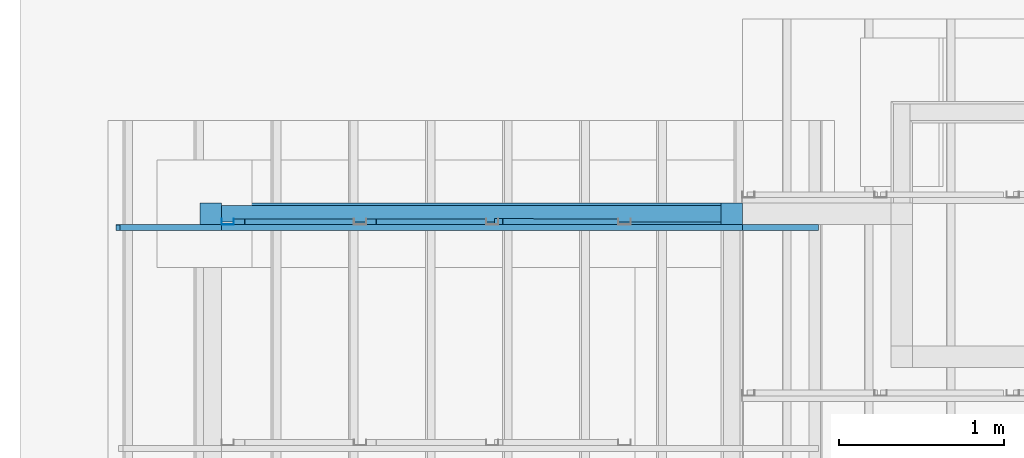
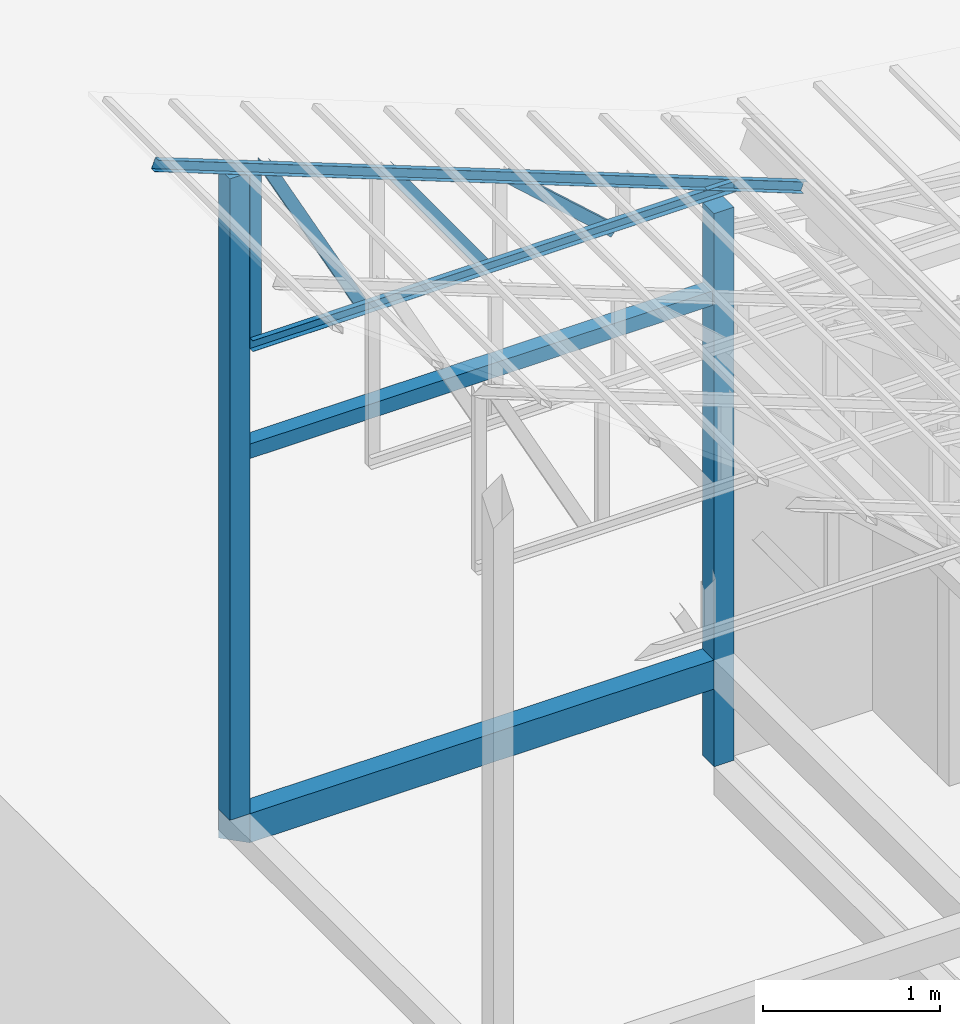
# One storey, part 14 of 22: 6 members, 4 beams, 1 element without a shape of its own.
"""IFC4 building model written with IfcOpenShell, lengths in millimetres."""

import ifcopenshell
import ifcopenshell.guid

model = None  # the IFC model being written
_history = None  # IfcOwnerHistory: only IFC2X3 demands one
_inside = {}  # id of a spatial element -> (the spatial element, [elements in it])
_under = {}  # id of a project, library or spatial element -> (it, [spatial elements below it])
_declared = {}  # id of a project -> (the project, [libraries it declares])
_typed = {}  # id of a type object -> (the type object, [elements of that type])
_made_of = {}  # id of a material, layer set ... -> (it, [elements and type objects made of it])


def new_model(schema):
    """Start an empty IFC model of exactly this schema.

    Asked for "IFC4X3", IfcOpenShell would pick the latest addendum, in which some entities
    have other attributes; the version numbers below select the first issue.
    IFC2X3 requires an IfcOwnerHistory on every rooted entity: one is made here for all.
    """
    global model, _history
    if schema == "IFC4X3":
        model = ifcopenshell.file(schema_version=(4, 3, 0, 0))
    else:
        model = ifcopenshell.file(schema=schema)
    _inside.clear()
    _under.clear()
    _declared.clear()
    _typed.clear()
    _made_of.clear()
    _history = None
    if model.schema == "IFC2X3":
        org = make("IfcOrganization", Name="unknown")
        user = make(
            "IfcPersonAndOrganization",
            ThePerson=make("IfcPerson", FamilyName="unknown"),
            TheOrganization=org,
        )
        app = make(
            "IfcApplication",
            ApplicationDeveloper=org,
            Version="unknown",
            ApplicationFullName="unknown",
            ApplicationIdentifier="unknown",
        )
        _history = make(
            "IfcOwnerHistory",
            OwningUser=user,
            OwningApplication=app,
            ChangeAction="ADDED",
            CreationDate=0,
        )
    return model


def make(cls, **values):
    """One entity of the class cls with the attributes given. An attribute that is None is left unset."""
    return model.create_entity(
        cls, **{name: value for name, value in values.items() if value is not None}
    )


def entity(cls, *values):
    """Any entity or typed value of the class cls, its attributes in the order of the schema. None: left unset."""
    e = model.create_entity(cls)
    for i, value in enumerate(values):
        if value is not None:
            e[i] = value
    return e


def rooted(cls, **values):
    """An entity with a GlobalId (a new one), such as an element, a storey or a relation."""
    return make(cls, GlobalId=ifcopenshell.guid.new(), OwnerHistory=_history, **values)


def si_unit(unit_type, name, prefix=None):
    """IfcSIUnit, for example si_unit("LENGTHUNIT", "METRE", prefix="MILLI")."""
    return make("IfcSIUnit", UnitType=unit_type, Prefix=prefix, Name=name)


def converted_unit(unit_type, name, factor, base, dimensions=None, offset=None):
    """IfcConversionBasedUnit, such as the inch: factor (a typed value) times the base unit."""
    return make(
        "IfcConversionBasedUnit"
        if offset is None
        else "IfcConversionBasedUnitWithOffset",
        ConversionOffset=offset,
        Dimensions=None
        if dimensions is None
        else entity("IfcDimensionalExponents", *dimensions),
        UnitType=unit_type,
        Name=name,
        ConversionFactor=make(
            "IfcMeasureWithUnit", ValueComponent=factor, UnitComponent=base
        ),
    )


def assignment(units):
    """IfcUnitAssignment: the units of a project."""
    return None if units is None else make("IfcUnitAssignment", Units=units)


def point(xyz):
    """IfcCartesianPoint."""
    return None if xyz is None else make("IfcCartesianPoint", Coordinates=xyz)


def direction(xyz):
    """IfcDirection."""
    return None if xyz is None else make("IfcDirection", DirectionRatios=xyz)


def frame(location, z_axis=None, x_axis=None):
    """IfcAxis2Placement3D, a coordinate frame: its origin and axes. An axis left out is left unset."""
    return make(
        "IfcAxis2Placement3D",
        Location=point(location),
        Axis=direction(z_axis),
        RefDirection=direction(x_axis),
    )


def frame_2d(location, x_axis=None):
    """IfcAxis2Placement2D, a coordinate frame in the plane: its origin and x axis."""
    return make(
        "IfcAxis2Placement2D", Location=point(location), RefDirection=direction(x_axis)
    )


def origin_with_axes():
    """The frame at (0, 0, 0) with the z axis (0, 0, 1) and the x axis (1, 0, 0) written out."""
    return frame((0.0, 0.0, 0.0), z_axis=(0.0, 0.0, 1.0), x_axis=(1.0, 0.0, 0.0))


def origin_2d_with_axis():
    """The frame at (0, 0) in the plane with the x axis (1, 0) written out."""
    return frame_2d((0.0, 0.0), x_axis=(1.0, 0.0))


def place(relative_to, where):
    """IfcLocalPlacement: puts the frame where relative to a parent placement (None: the world)."""
    return make(
        "IfcLocalPlacement", PlacementRelTo=relative_to, RelativePlacement=where
    )


def context(
    kind, dimensions, precision=None, world=None, true_north=None, identifier=None
):
    """IfcGeometricRepresentationContext, for example the 3D "Model" context."""
    return make(
        "IfcGeometricRepresentationContext",
        ContextIdentifier=identifier,
        ContextType=kind,
        CoordinateSpaceDimension=dimensions,
        Precision=precision,
        WorldCoordinateSystem=world,
        TrueNorth=true_north,
    )


def subcontext(parent, identifier, kind, view, scale=None):
    """IfcGeometricRepresentationSubContext, for example "Body" below "Model"."""
    return make(
        "IfcGeometricRepresentationSubContext",
        ContextIdentifier=identifier,
        ContextType=kind,
        ParentContext=parent,
        TargetScale=scale,
        TargetView=view,
    )


def project(units=None, contexts=None):
    """IfcProject with its units and contexts."""
    return rooted(
        "IfcProject",
        Name="project",
        RepresentationContexts=contexts,
        UnitsInContext=assignment(units),
    )


def spatial(cls, under=None, at=None, **own):
    """A site, building, storey or space (cls), placed at a placement, below another one or the project."""
    s = rooted(cls, ObjectPlacement=at, **own)
    if under is not None:
        _under.setdefault(under.id(), (under, []))[1].append(s)
    return s


def point_list(points):
    """IfcCartesianPointList2D or 3D."""
    cls = (
        "IfcCartesianPointList2D" if len(points[0]) == 2 else "IfcCartesianPointList3D"
    )
    return make(cls, CoordList=points)


def indexed_curve(points, segments=None, self_intersect=None):
    """IfcIndexedPolyCurve: lines and arcs through numbered points (the first is 1)."""
    return make(
        "IfcIndexedPolyCurve",
        Points=point_list(points),
        Segments=segments,
        SelfIntersect=self_intersect,
    )


def profile(cls, at=None, kind="AREA", **sizes):
    """A parametric profile (cls). Its sizes go by their IFC names, for example OverallWidth=200.0."""
    return make(cls, ProfileType=kind, Position=at, **sizes)


def rectangle(**sizes):
    """IfcRectangleProfileDef."""
    return profile("IfcRectangleProfileDef", **sizes)


def c_section(**sizes):
    """IfcCShapeProfileDef."""
    return profile("IfcCShapeProfileDef", **sizes)


def outline(outer, holes=None, kind="AREA"):
    """IfcArbitraryClosedProfileDef: a profile drawn as a closed curve; with holes, ...WithVoids."""
    if holes is None:
        return make("IfcArbitraryClosedProfileDef", ProfileType=kind, OuterCurve=outer)
    return make(
        "IfcArbitraryProfileDefWithVoids",
        ProfileType=kind,
        OuterCurve=outer,
        InnerCurves=holes,
    )


def extrude(swept, where, along, depth):
    """IfcExtrudedAreaSolid: the profile swept, set in the frame where, extruded along a direction by depth."""
    return make(
        "IfcExtrudedAreaSolid",
        SweptArea=swept,
        Position=where,
        ExtrudedDirection=direction(along),
        Depth=depth,
    )


def clip(a, b, op="DIFFERENCE"):
    """IfcBooleanClippingResult: the solid a cut by the half space b."""
    return make(
        "IfcBooleanClippingResult", Operator=op, FirstOperand=a, SecondOperand=b
    )


def halfspace(plane, agree):
    """IfcHalfSpaceSolid: all space on one side of the plane z = 0 of the frame plane."""
    return make(
        "IfcHalfSpaceSolid",
        BaseSurface=make("IfcPlane", Position=plane),
        AgreementFlag=agree,
    )


def shape(context_of_items, identifier, shape_type, items):
    """IfcShapeRepresentation: the items that make up one representation, for example the "Body"."""
    return make(
        "IfcShapeRepresentation",
        ContextOfItems=context_of_items,
        RepresentationIdentifier=identifier,
        RepresentationType=shape_type,
        Items=items,
    )


def material(Name=None, Category=None):
    """IfcMaterial."""
    return make("IfcMaterial", Name=Name, Category=Category)


def material_profile(
    of_material, cross_section, Name=None, Category=None, Priority=None
):
    """IfcMaterialProfile: a cross section and its material."""
    return make(
        "IfcMaterialProfile",
        Name=Name,
        Material=of_material,
        Profile=cross_section,
        Priority=Priority,
        Category=Category,
    )


def profile_set(profiles, Name=None, composite=None):
    """IfcMaterialProfileSet."""
    return make(
        "IfcMaterialProfileSet",
        Name=Name,
        MaterialProfiles=profiles,
        CompositeProfile=composite,
    )


def profile_usage(for_profile_set, cardinal=None, extent=None):
    """IfcMaterialProfileSetUsage: how a profile set lies along its element."""
    return make(
        "IfcMaterialProfileSetUsage",
        ForProfileSet=for_profile_set,
        CardinalPoint=cardinal,
        ReferenceExtent=extent,
    )


def made_of(thing, what):
    """Note that an element or type object is made of a material, layer set ...; save() writes the relation."""
    if what is not None:
        _made_of.setdefault(what.id(), (what, []))[1].append(thing)
    return thing


def type_object(cls, material=None, **own):
    """A type object (cls), such as IfcWallType, which elements share."""
    return made_of(rooted(cls, **own), material)


def element(
    cls,
    number,
    at=None,
    inside=None,
    cuts=None,
    type_object=None,
    material=None,
    context=None,
    identifier="Body",
    shape_type=None,
    held_by="IfcProductDefinitionShape",
    body=None,
    shapes=None,
    **own,
):
    """One element of the class cls, such as IfcWall. Its Tag is "e" and its number.

    at: its placement. inside: the storey or other place that contains it. cuts: it is an
    opening in that element (IfcRelVoidsElement). A single representation is given by context,
    identifier, shape_type and body (its items); several are given by shapes. held_by: the class
    of the entity that holds the representations. save() writes the other relations.
    """
    e = rooted(cls, Tag="e%d" % number, ObjectPlacement=at, **own)
    if body is not None:
        shapes = [shape(context, identifier, shape_type, body)]
    if shapes is not None:
        e.Representation = make(held_by, Representations=shapes)
    if inside is not None:
        _inside.setdefault(inside.id(), (inside, []))[1].append(e)
    if cuts is not None:
        rooted(
            "IfcRelVoidsElement", RelatingBuildingElement=cuts, RelatedOpeningElement=e
        )
    if type_object is not None:
        _typed.setdefault(type_object.id(), (type_object, []))[1].append(e)
    return made_of(e, material)


def aggregate(whole, parts):
    """IfcRelAggregates: a whole, such as a stair, and the parts it consists of."""
    return rooted("IfcRelAggregates", RelatingObject=whole, RelatedObjects=parts)


def save(model, path):
    """Write the relations noted so far, then the file.

    IfcRelAggregates (storeys below a building ...), IfcRelContainedInSpatialStructure (elements
    in a storey), IfcRelDefinesByType, IfcRelAssociatesMaterial and IfcRelDeclares: one each for
    every whole, place, type object, material and project.
    """
    for whole, parts in _under.values():
        aggregate(whole, parts)
    for where, things in _inside.values():
        rooted(
            "IfcRelContainedInSpatialStructure",
            RelatedElements=things,
            RelatingStructure=where,
        )
    for kind, things in _typed.values():
        rooted("IfcRelDefinesByType", RelatedObjects=things, RelatingType=kind)
    for what, things in _made_of.values():
        rooted("IfcRelAssociatesMaterial", RelatedObjects=things, RelatingMaterial=what)
    for by, libraries in _declared.values():
        rooted("IfcRelDeclares", RelatingContext=by, RelatedDefinitions=libraries)
    model.write(path)


model = new_model("IFC4")

# Units and contexts
model_context = context("Model", 3, precision=1e-05, world=origin_with_axes())
plan_context = context("Plan", 2, precision=1e-05, world=origin_2d_with_axis())
body_context = subcontext(model_context, "Body", "Model", "MODEL_VIEW")
ifc_project = project(units=[si_unit("VOLUMEUNIT", "CUBIC_METRE"), si_unit("LENGTHUNIT", "METRE", prefix="MILLI"), si_unit("AREAUNIT", "SQUARE_METRE"), converted_unit("PLANEANGLEUNIT", "degree", entity("IfcReal", 0.0174532925199433), si_unit("PLANEANGLEUNIT", "RADIAN"), dimensions=[0, 0, 0, 0, 0, 0, 0])], contexts=[model_context, plan_context])

# Site, building, storey
site_placement = place(None, origin_with_axes())
site = spatial("IfcSite", under=ifc_project, at=site_placement)
building_placement = place(site_placement, origin_with_axes())
building = spatial("IfcBuilding", under=site, at=building_placement, Name="2")
storey_placement = place(building_placement, frame((0.0, 0.0, 200.000002980232), z_axis=(0.0, 0.0, 1.0), x_axis=(1.0, 0.0, 0.0)))
storey = spatial("IfcBuildingStorey", under=building, at=storey_placement)

# Beams
ifc_material_1 = material(Name="Concrete")
ifc_material_profile_1 = material_profile(ifc_material_1, outline(indexed_curve([(-65.0, 99.9999923706055), (65.0, 99.9999923706055), (65.0, -99.9999923706055), (-65.0, -99.9999923706055), (-65.0, 99.9999923706055)])))
ifc_profile_set_1 = profile_set([ifc_material_profile_1])
ifc_profile_usage_1 = profile_usage(ifc_profile_set_1, cardinal=2)
beam_type_1 = type_object("IfcBeamType", PredefinedType="BEAM", material=ifc_profile_set_1)
beam_1_placement = place(storey_placement, frame((-3934.99302864075, 17300.0011444092, 535.005614161491), z_axis=(-0.999999999999962, -1.94707169498535e-07, 1.9470718370939e-07), x_axis=(1.94707183709392e-07, -0.999999999999974, 1.19209289550778e-07)))
element("IfcBeam", 1, at=beam_1_placement, inside=storey, type_object=beam_type_1, material=ifc_profile_usage_1, Name="Beam", PredefinedType="BEAM", context=body_context, shape_type="Clipping", body=[
    clip(clip(extrude(outline(indexed_curve([(-65.0, 99.9999923706055), (65.0, 99.9999923706055), (65.0, -99.9999923706055), (-65.0, -99.9999923706055), (-65.0, 99.9999923706055)])), frame((0.0, 100.0, 0.0), z_axis=(0.0, 0.0, 1.0), x_axis=(1.0, 0.0, 0.0)), (0.0, 0.0, 1.0), 3280.00188432041), halfspace(frame((-65.0000348687172, -735.007286071777, 3280.00164031982), z_axis=(0.707104027271271, -1.79825931923006e-07, 0.70710951089859), x_axis=(-2.54313262246507e-07, -0.999999999999968, 0.0)), False)), halfspace(frame((-65.0013014674187, -735.00669002533, -4.32300808483888e-05), z_axis=(0.70710301399231, 1.00769234734344e-07, -0.707110524177551), x_axis=(1.42509977669871e-07, -0.99999999999999, 0.0)), False)),
])
ifc_material_profile_2 = material_profile(ifc_material_1, rectangle(XDim=130.000015258789, YDim=130.000015258789, kind="CURVE"))
ifc_profile_set_2 = profile_set([ifc_material_profile_2])
ifc_profile_usage_2 = profile_usage(ifc_profile_set_2, cardinal=5)
beam_type_2 = type_object("IfcBeamType", PredefinedType="BEAM", material=ifc_profile_set_2)
beam_2_placement = place(storey_placement, frame((-7149.99485015869, 17300.0030517578, 735.004410147667), z_axis=(0.0, 0.0, 1.0), x_axis=(1.0, 0.0, 0.0)))
element("IfcBeam", 2, at=beam_2_placement, inside=storey, type_object=beam_type_2, material=ifc_profile_usage_2, Name="Column", PredefinedType="BEAM", context=body_context, shape_type="SweptSolid", body=[
    extrude(rectangle(XDim=130.000015258789, YDim=130.000015258789, kind="CURVE"), origin_with_axes(), (0.0, 0.0, 1.0), 4411.20426507743),
])
ifc_profile_usage_3 = profile_usage(ifc_profile_set_2, cardinal=5)
beam_3_placement = place(storey_placement, frame((-3999.99308586121, 17300.0011444092, 4.47034838035876e-05), z_axis=(0.0, 0.0, 1.0), x_axis=(1.0, 0.0, 0.0)))
element("IfcBeam", 3, at=beam_3_placement, inside=storey, type_object=beam_type_2, material=ifc_profile_usage_3, Name="Column", PredefinedType="BEAM", context=body_context, shape_type="SweptSolid", body=[
    extrude(rectangle(XDim=130.000015258789, YDim=130.000015258789, kind="CURVE"), origin_with_axes(), (0.0, 0.0, 1.0), 3804.94855106575),
])

# Assembly, members
assembly_placement = place(storey_placement, frame((-3938.51041793823, 5099.00283813477, 3935.3459328413), z_axis=(0.0, 0.0, 1.0), x_axis=(1.0, 0.0, 0.0)))
assembly = element("IfcElementAssembly", 4, at=assembly_placement, inside=storey, Name="2")
ifc_material_2 = material(Name="STEEL")
ifc_material_profile_3 = material_profile(ifc_material_2, c_section(Depth=75.0, Width=35.0, WallThickness=1.0, Girth=1.0, kind="CURVE"))
ifc_profile_set_3 = profile_set([ifc_material_profile_3])
ifc_profile_usage_4 = profile_usage(ifc_profile_set_3, cardinal=7)
member_type = type_object("IfcMemberType", Name="C75", PredefinedType="CHORD", material=ifc_profile_set_3)
member_1_placement = place(assembly_placement, frame((-1445.26290893555, 12171.9589233398, 624.074935913086), z_axis=(0.745142107017777, -0.00102660805644996, -0.66690493057482), x_axis=(0.00137753843534741, 0.999999051193456, -2.17762747561669e-07)))
member_1 = element("IfcMember", 5, at=member_1_placement, type_object=member_type, material=ifc_profile_usage_4, Name="Member", context=body_context, shape_type="SweptSolid", body=[
    extrude(c_section(Depth=75.0, Width=35.0, WallThickness=1.0, Girth=1.0, kind="CURVE"), frame((-17.5, -37.5, 0.0), z_axis=(0.0, 0.0, 1.0), x_axis=(1.0, 0.0, 0.0)), (0.0, 0.0, 1.0), 937.808496265298),
])
ifc_profile_usage_5 = profile_usage(ifc_profile_set_3, cardinal=1)
member_2_placement = place(assembly_placement, frame((-3146.51107788086, 12170.9976196289, 1265.15865325928), z_axis=(-8.74227410463377e-08, -1.50995830949794e-07, -0.999999999999985), x_axis=(-3.13916473260159e-07, 0.999999999999939, -1.50995802528077e-07)))
member_2 = element("IfcMember", 6, at=member_2_placement, type_object=member_type, material=ifc_profile_usage_5, Name="Member", context=body_context, shape_type="SweptSolid", body=[
    extrude(c_section(Depth=75.0, Width=35.0, WallThickness=1.0, Girth=1.0, kind="CURVE"), frame((-17.5, 37.5, 0.0), z_axis=(0.0, 0.0, 1.0), x_axis=(1.0, 0.0, 0.0)), (0.0, 0.0, 1.0), 1266.51238309135),
])
ifc_profile_usage_6 = profile_usage(ifc_profile_set_3, cardinal=9)
member_3_placement = place(assembly_placement, frame((-3006.42156600952, 12135.9977722168, 1241.45650863647), z_axis=(0.468464370953309, -3.43728484817469e-07, -0.88348238983423), x_axis=(6.7154434191237e-07, 0.999999999999774, -3.29761675743537e-08)))
member_3 = element("IfcMember", 7, at=member_3_placement, type_object=member_type, material=ifc_profile_usage_6, Name="Member", context=body_context, shape_type="SweptSolid", body=[
    extrude(c_section(Depth=75.0, Width=35.0, WallThickness=1.0, Girth=1.0, kind="CURVE"), frame((17.5, -37.5, 0.0), z_axis=(0.0, 0.0, 1.0), x_axis=(1.0, 0.0, 0.0)), (0.0, 0.0, 1.0), 1399.63894386164),
])
ifc_profile_usage_7 = profile_usage(ifc_profile_set_3, cardinal=1)
member_4_placement = place(assembly_placement, frame((3.51285934448242, 12100.9979248047, -1.35517120361328), z_axis=(-0.999999999999812, -4.33125762810878e-07, 4.33125762810878e-07), x_axis=(4.33125762810919e-07, -0.999999999999906, -1.13742348872837e-13)))
member_4 = element("IfcMember", 8, at=member_4_placement, type_object=member_type, material=ifc_profile_usage_7, Name="Member", context=body_context, shape_type="SweptSolid", body=[
    extrude(c_section(Depth=75.0, Width=35.0, WallThickness=1.0, Girth=1.0, kind="CURVE"), frame((-17.5, 37.5, 0.0), z_axis=(0.0, 0.0, 1.0), x_axis=(1.0, 0.0, 0.0)), (0.0, 0.0, 1.0), 3150.02386296032),
])
ifc_profile_usage_8 = profile_usage(ifc_profile_set_3, cardinal=1)
member_5_placement = place(assembly_placement, frame((438.234329223633, 12100.9998321533, -169.034004211426), z_axis=(-0.933001152035968, -8.32115964913738e-07, 0.359873380925658), x_axis=(9.09962921013707e-07, -0.999999999999585, 4.6906695416718e-08)))
member_5 = element("IfcMember", 9, at=member_5_placement, type_object=member_type, material=ifc_profile_usage_8, Name="Member", context=body_context, shape_type="SweptSolid", body=[
    extrude(c_section(Depth=75.0, Width=35.0, WallThickness=1.0, Girth=1.0, kind="CURVE"), frame((-17.5, 37.5, 0.0), z_axis=(0.0, 0.0, 1.0), x_axis=(1.0, 0.0, 0.0)), (0.0, 0.0, 1.0), 4528.50305889162),
])
ifc_profile_usage_9 = profile_usage(ifc_profile_set_3, cardinal=3)
member_6_placement = place(assembly_placement, frame((-2271.51107788086, 12135.9977722168, 894.618034362793), z_axis=(0.578723368640778, -7.49756619914683e-07, -0.815523919078103), x_axis=(1.02917226740772e-06, 0.999999999999453, -1.89020340712783e-07)))
member_6 = element("IfcMember", 10, at=member_6_placement, type_object=member_type, material=ifc_profile_usage_9, Name="Member", context=body_context, shape_type="SweptSolid", body=[
    extrude(c_section(Depth=75.0, Width=35.0, WallThickness=1.0, Girth=1.0, kind="CURVE"), frame((17.5, 37.5, 0.0), z_axis=(0.0, 0.0, 1.0), x_axis=(1.0, 0.0, 0.0)), (0.0, 0.0, 1.0), 1142.30360336039),
])
aggregate(assembly, [member_1, member_2, member_3, member_4, member_5, member_6])

# Beam
ifc_material_profile_4 = material_profile(ifc_material_1, rectangle(XDim=100.0, YDim=100.0))
ifc_profile_set_4 = profile_set([ifc_material_profile_4])
ifc_profile_usage_10 = profile_usage(ifc_profile_set_4, cardinal=2)
beam_type_3 = type_object("IfcBeamType", PredefinedType="BEAM", material=ifc_profile_set_4)
beam_4_placement = place(storey_placement, frame((-7084.9986076355, 17300.0030517578, 3165.00024497509), z_axis=(0.999999999999932, -1.9470714107682e-07, 3.13916473260157e-07), x_axis=(1.94707183709391e-07, 0.99999999999997, -1.49011611938472e-07)))
element("IfcBeam", 11, at=beam_4_placement, inside=storey, type_object=beam_type_3, material=ifc_profile_usage_10, Name="Beam", PredefinedType="BEAM", context=body_context, shape_type="SweptSolid", body=[
    extrude(rectangle(XDim=100.0, YDim=100.0), frame((0.0, 50.0, 0.0), z_axis=(0.0, 0.0, 1.0), x_axis=(1.0, 0.0, 0.0)), (0.0, 0.0, 1.0), 3020.0033867421),
])

save(model, "model.ifc")
